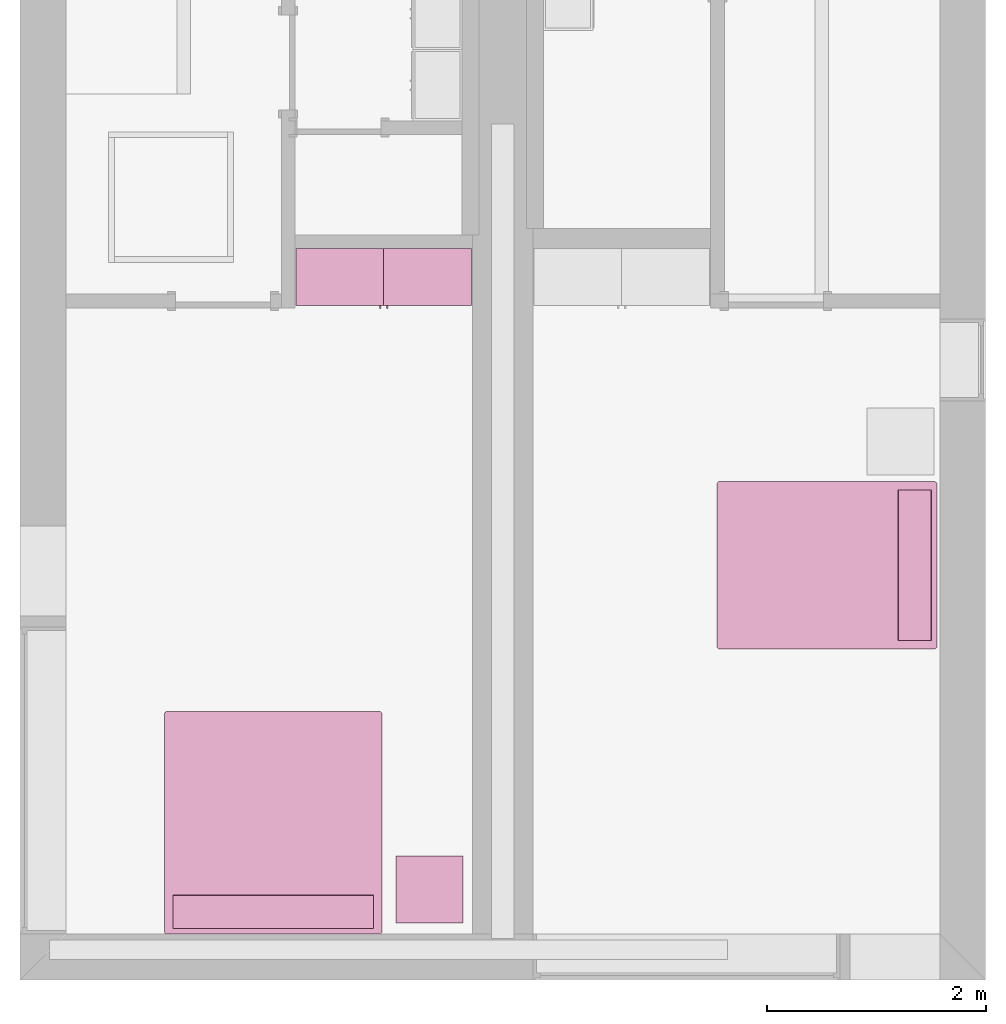
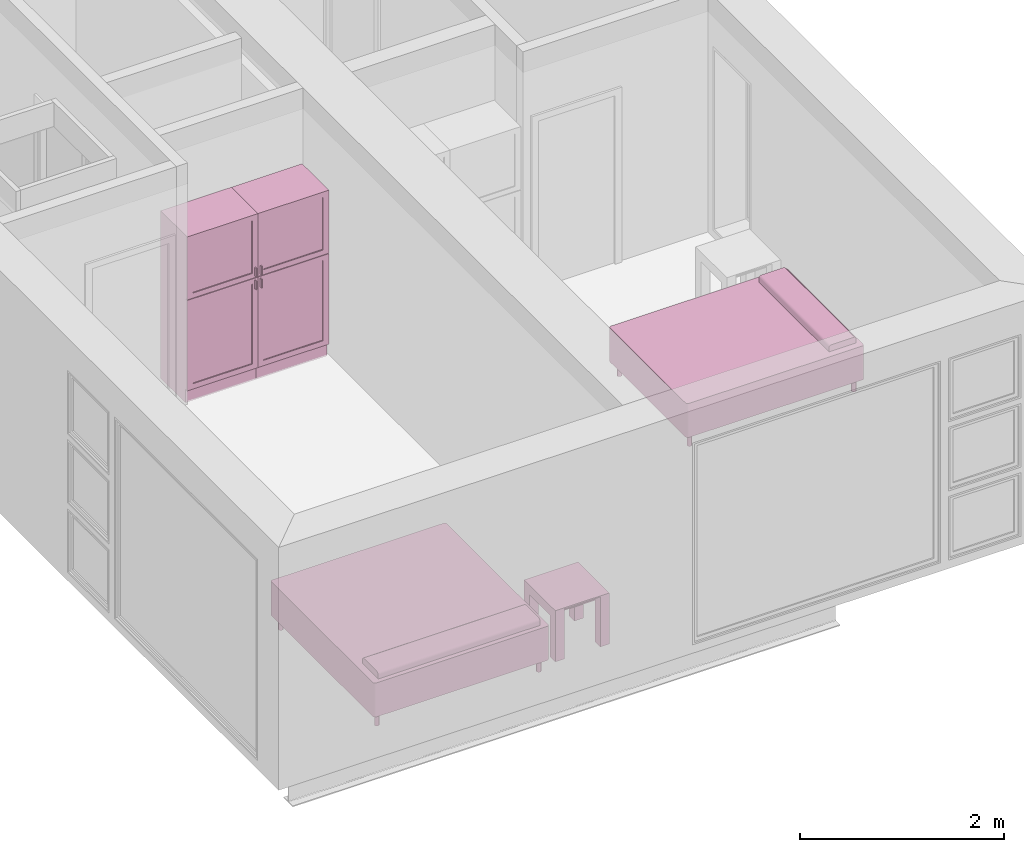
# One storey, part 7 of 10: 5 furnishings, 2 openings.
"""IFC2X3 building model written with IfcOpenShell, lengths in metres."""

from ifc_helpers import new_model, entity, si_unit, converted_unit, derived_unit, direction, frame, frame_2d, origin, origin_2d_with_axis, place, context, subcontext, project, spatial, polyline, circle_curve, parameter, trimmed, segment, composite_curve, rectangle, circle, outline, extrude, source, transform, mapped, material, material_list, type_object, type_shapes, element, save


model = new_model("IFC2X3")

# Units and contexts
model_context = context("Model", 3, precision=1e-05, world=origin(), true_north=direction((6.12303176911189e-17, 1.0)))
body_context = subcontext(model_context, "Body", "Model", "MODEL_VIEW")
ifc_project = project(units=[derived_unit("USERDEFINED", [(si_unit("LENGTHUNIT", "METRE"), -2), (si_unit("TIMEUNIT", "SECOND"), -2), (si_unit("MASSUNIT", "GRAM", prefix="KILO"), 1)]), si_unit("FREQUENCYUNIT", "HERTZ"), si_unit("LENGTHUNIT", "METRE"), si_unit("ILLUMINANCEUNIT", "LUX"), derived_unit("LINEARVELOCITYUNIT", [(si_unit("TIMEUNIT", "SECOND"), -1), (si_unit("LENGTHUNIT", "METRE"), 1)]), si_unit("POWERUNIT", "WATT"), si_unit("LUMINOUSINTENSITYUNIT", "CANDELA"), si_unit("AREAUNIT", "SQUARE_METRE"), si_unit("VOLUMEUNIT", "CUBIC_METRE"), si_unit("ELECTRICVOLTAGEUNIT", "VOLT"), si_unit("PRESSUREUNIT", "PASCAL"), converted_unit("PLANEANGLEUNIT", "DEGREE", entity("IfcRatioMeasure", 0.0174532925199433), si_unit("PLANEANGLEUNIT", "RADIAN"), dimensions=[0, 0, 0, 0, 0, 0, 0]), si_unit("THERMODYNAMICTEMPERATUREUNIT", "DEGREE_CELSIUS"), si_unit("MASSUNIT", "GRAM", prefix="KILO"), derived_unit("VOLUMETRICFLOWRATEUNIT", [(si_unit("LENGTHUNIT", "METRE"), 3), (si_unit("TIMEUNIT", "SECOND"), -1)]), si_unit("TIMEUNIT", "SECOND"), si_unit("LUMINOUSFLUXUNIT", "LUMEN"), derived_unit("USERDEFINED", [(si_unit("LUMINOUSFLUXUNIT", "LUMEN"), 1), (si_unit("TIMEUNIT", "SECOND"), 3), (si_unit("MASSUNIT", "GRAM", prefix="KILO"), -1), (si_unit("LENGTHUNIT", "METRE"), -2)]), si_unit("FORCEUNIT", "NEWTON", prefix="KILO"), si_unit("ELECTRICCURRENTUNIT", "AMPERE"), derived_unit("THERMALTRANSMITTANCEUNIT", [(si_unit("TIMEUNIT", "SECOND"), -3), (si_unit("THERMODYNAMICTEMPERATUREUNIT", "KELVIN"), -1), (si_unit("MASSUNIT", "GRAM", prefix="KILO"), 1)])], contexts=[model_context])

# Site, building, storey, space
site_placement = place(None, origin())
site = spatial("IfcSite", under=ifc_project, at=site_placement, CompositionType="ELEMENT")
building_placement = place(site_placement, origin())
building = spatial("IfcBuilding", under=site, at=building_placement, CompositionType="ELEMENT")
storey_placement = place(building_placement, frame((0.0, 0.0, 3.10000000000038)))
storey = spatial("IfcBuildingStorey", under=building, at=storey_placement, Name="Level 2", CompositionType="ELEMENT", Elevation=3.10000000000038)
space_1_placement = place(storey_placement, origin())
space_1 = spatial("IfcSpace", under=storey, at=space_1_placement, CompositionType="ELEMENT", InteriorOrExteriorSpace="INTERNAL")

# Furnishing, opening
ifc_material_1 = material(Name="Cabinets")
ifc_material_2 = material(Name="Cabinets - Handles")
ifc_material_3 = material(Name="Cabinets - Panel")
ifc_material_list_1 = material_list([ifc_material_1, ifc_material_2, ifc_material_3])
ifc_material_list_2 = material_list([ifc_material_1, ifc_material_2, ifc_material_3])
furniture_type_1 = type_object("IfcFurnitureType", Name="800 mm", AssemblyPlace="NOTDEFINED", material=ifc_material_list_2)
shared_shape_1 = source(origin(), body_context, "Body", "SweptSolid", [
    extrude(rectangle(XDim=0.00634999999999998, YDim=0.672999999999998, at=origin_2d_with_axis()), frame((0.0187377049180256, -0.504125, 0.225087499999839), z_axis=(0.0, 0.0, 1.0), x_axis=(0.0, 1.0, 0.0)), (0.0, 0.0, 1.0), 0.955960536695974),
    extrude(rectangle(XDim=0.0254, YDim=0.0125322316306447, at=frame_2d((0.0, -3.38271077815477e-17), x_axis=(1.0, 0.0))), frame((0.387071589102702, -0.532700000000001, 1.11754803669582), z_axis=(0.0, 0.0, 1.0), x_axis=(0.0, 1.0, 0.0)), (0.0, 0.0, 1.0), 0.101599999999998),
    extrude(rectangle(XDim=0.00634999999999998, YDim=0.672999999999998, at=origin_2d_with_axis()), frame((0.0187377049180261, -0.504125, 1.30804803669582), z_axis=(0.0, 0.0, 1.0), x_axis=(0.0, 1.0, 0.0)), (0.0, 0.0, 1.0), 0.62845196330414),
    extrude(outline(polyline([(-0.172299999999634, 0.558941666666897), (-0.172300000000835, -1.2794708333333), (0.328649999999164, -1.27947083333363), (0.32865000000047, 0.720529166666412), (-0.156349999999529, 0.720529166666729), (-0.156349999999635, 0.558941666666897), (-0.172299999999634, 0.558941666666897)])), frame((-0.381262295081959, -0.328649999999999, 0.720529166666627), z_axis=(-1.0, 0.0, 0.0), x_axis=(0.0, 1.0, 0.0)), (0.0, 0.0, -1.0), 0.8),
    extrude(outline(polyline([(-0.376138481652111, -0.4), (0.376138481652111, -0.4), (0.376138481652111, 0.4), (-0.376138481652111, 0.4), (-0.376138481652111, -0.4)]), holes=[polyline([(-0.312638481652032, -0.336499999999999), (-0.312638481652032, 0.336499999999999), (0.315813481652108, 0.336499999999999), (0.315813481652108, -0.336499999999999), (-0.312638481652032, -0.336499999999999)])]), frame((0.0187377049180258, -0.52, 1.62386151834792), z_axis=(0.0, 1.0, 0.0), x_axis=(0.0, 0.0, -1.0)), (0.0, 0.0, 1.0), 0.01905),
    extrude(outline(polyline([(-0.4, -0.539892768347997), (0.4, -0.539892768347997), (0.4, 0.539892768347997), (-0.4, 0.539892768347997), (-0.4, -0.539892768347997)]), holes=[polyline([(-0.336499999999999, 0.479567768347999), (0.336499999999999, 0.479567768347999), (0.336499999999999, -0.476392768347979), (-0.336499999999999, -0.476392768347979), (-0.336499999999999, 0.479567768347999)])]), frame((0.0187377049180257, -0.52, 0.701480268347818), z_axis=(0.0, 1.0, 0.0), x_axis=(-1.0, 0.0, 0.0)), (0.0, 0.0, 1.0), 0.01905),
    extrude(rectangle(XDim=0.0254, YDim=0.0125322316306444, at=frame_2d((0.0, 3.38271077815477e-17), x_axis=(1.0, 0.0))), frame((0.387071589102703, -0.532700000000001, 1.26994803669581), z_axis=(0.0, 0.0, 1.0), x_axis=(0.0, 1.0, 0.0)), (0.0, 0.0, 1.0), 0.1016),
    extrude(rectangle(XDim=0.01905, YDim=0.761899999999999, at=origin_2d_with_axis()), frame((0.018737704918025, -0.009525, 0.180637499999846), z_axis=(0.0, 0.0, 1.0), x_axis=(0.0, 1.0, 0.0)), (0.0, 0.0, 1.0), 1.80031250000011),
])
type_shapes(furniture_type_1, [shared_shape_1])
furnishing_1_placement = place(space_1_placement, frame((2.89526229508197, -11.134, 0.0)))
furnishing_1 = element("IfcFurnishingElement", 1, at=furnishing_1_placement, inside=space_1, type_object=furniture_type_1, material=ifc_material_list_1, ObjectType="800 mm", context=body_context, shape_type="MappedRepresentation", body=[
    mapped(shared_shape_1, transform((0.0, 0.0, 0.0), scale=1.0)),
])
opening_1_placement = place(storey_placement, frame((2.89526229508197, -11.134, 3.1000000000002)))
element("IfcOpeningElement", 2, at=opening_1_placement, cuts=furnishing_1, ObjectType="Opening", context=body_context, shape_type="SweptSolid", body=[
    extrude(rectangle(XDim=1.80031250000011, YDim=0.761899999999999, at=frame_2d((5.55111512312578e-17, 0.0), x_axis=(1.0, 0.0))), frame((0.0187377049180235, -0.50095, -2.01920625000048), z_axis=(0.0, 1.0, 0.0), x_axis=(0.0, 0.0, -1.0)), (0.0, 0.0, 1.0), 0.50095),
])

ifc_material_list_3 = material_list([ifc_material_1, ifc_material_2, ifc_material_3])
ifc_material_list_4 = material_list([ifc_material_1, ifc_material_2, ifc_material_3])
furniture_type_2 = type_object("IfcFurnitureType", Name="800 mm", AssemblyPlace="NOTDEFINED", material=ifc_material_list_4)
shared_shape_2 = source(origin(), body_context, "Body", "SweptSolid", [
    extrude(rectangle(XDim=0.0125322316306447, YDim=0.0254, at=frame_2d((-3.38271077815477e-17, 0.0), x_axis=(1.0, 0.0))), frame((0.387071589102702, 0.532700000000001, 1.11754803669582), z_axis=(0.0, 0.0, 1.0), x_axis=(-1.0, 0.0, 0.0)), (0.0, 0.0, 1.0), 0.101599999999998),
    extrude(rectangle(XDim=0.672999999999998, YDim=0.00634999999999998, at=frame_2d((0.0, 6.76542155630955e-17), x_axis=(1.0, 0.0))), frame((0.0187377049180256, 0.504125, 0.225087499999839), z_axis=(0.0, 0.0, 1.0), x_axis=(-1.0, 0.0, 0.0)), (0.0, 0.0, 1.0), 0.955960536695974),
    extrude(rectangle(XDim=0.672999999999998, YDim=0.00634999999999998, at=frame_2d((0.0, 6.76542155630955e-17), x_axis=(1.0, 0.0))), frame((0.0187377049180261, 0.504125, 1.30804803669582), z_axis=(0.0, 0.0, 1.0), x_axis=(-1.0, 0.0, 0.0)), (0.0, 0.0, 1.0), 0.62845196330414),
    extrude(outline(polyline([(-0.558941666666786, -0.172299999999999), (1.27947083333342, -0.172299999999999), (1.27947083333342, 0.32865), (-0.720529166666629, 0.328649999999999), (-0.720529166666629, -0.15635), (-0.558941666666786, -0.15635), (-0.558941666666786, -0.172299999999999)])), frame((-0.38126229508196, 0.328649999999999, 0.720529166666629), z_axis=(1.0, 0.0, 0.0), x_axis=(0.0, 0.0, 1.0)), (0.0, 0.0, 1.0), 0.8),
    extrude(outline(polyline([(-0.4, -0.539892768347997), (0.4, -0.539892768347997), (0.4, 0.539892768347997), (-0.4, 0.539892768347997), (-0.4, -0.539892768347997)]), holes=[polyline([(-0.336499999999999, 0.479567768347999), (0.336499999999999, 0.479567768347999), (0.336499999999999, -0.476392768347979), (-0.336499999999999, -0.476392768347979), (-0.336499999999999, 0.479567768347999)])]), frame((0.0187377049180257, 0.50095, 0.701480268347818), z_axis=(0.0, 1.0, 0.0), x_axis=(-1.0, 0.0, 0.0)), (0.0, 0.0, 1.0), 0.01905),
    extrude(rectangle(XDim=0.0125322316306444, YDim=0.0254, at=frame_2d((3.38271077815477e-17, 0.0), x_axis=(1.0, 0.0))), frame((0.387071589102703, 0.532700000000001, 1.26994803669581), z_axis=(0.0, 0.0, 1.0), x_axis=(-1.0, 0.0, 0.0)), (0.0, 0.0, 1.0), 0.1016),
    extrude(outline(polyline([(-0.376138481652111, -0.4), (0.376138481652111, -0.4), (0.376138481652111, 0.4), (-0.376138481652111, 0.4), (-0.376138481652111, -0.4)]), holes=[polyline([(-0.312638481652032, -0.3365), (-0.312638481652032, 0.336499999999999), (0.315813481652108, 0.336499999999999), (0.315813481652108, -0.3365), (-0.312638481652032, -0.3365)])]), frame((0.0187377049180258, 0.50095, 1.62386151834792), z_axis=(0.0, 1.0, 0.0), x_axis=(0.0, 0.0, -1.0)), (0.0, 0.0, 1.0), 0.01905),
    extrude(rectangle(XDim=0.761899999999999, YDim=0.01905, at=origin_2d_with_axis()), frame((0.018737704918025, 0.009525, 0.180637499999846), z_axis=(0.0, 0.0, 1.0), x_axis=(-1.0, 0.0, 0.0)), (0.0, 0.0, 1.0), 1.80031250000011),
])
type_shapes(furniture_type_2, [shared_shape_2])
furnishing_2_placement = place(space_1_placement, frame((3.73273770491802, -11.134, 0.0), z_axis=(0.0, 0.0, 1.0), x_axis=(-1.0, 0.0, 0.0)))
furnishing_2 = element("IfcFurnishingElement", 3, at=furnishing_2_placement, inside=space_1, type_object=furniture_type_2, material=ifc_material_list_3, ObjectType="800 mm", context=body_context, shape_type="MappedRepresentation", body=[
    mapped(shared_shape_2, transform((0.0, 0.0, 0.0), scale=1.0)),
])
opening_2_placement = place(storey_placement, frame((3.73273770491802, -11.134, 3.1000000000002)))
element("IfcOpeningElement", 4, at=opening_2_placement, cuts=furnishing_2, ObjectType="Opening", context=body_context, shape_type="SweptSolid", body=[
    extrude(rectangle(XDim=1.80031250000011, YDim=0.761899999999999, at=frame_2d((5.55111512312578e-17, 0.0), x_axis=(1.0, 0.0))), frame((-0.0187377049180251, 0.0, -2.01920625000048), z_axis=(0.0, -1.0, 0.0), x_axis=(0.0, 0.0, -1.0)), (0.0, 0.0, 1.0), 0.50095),
])

# Furnishing
ifc_material_4 = material(Name="Wood - Teak")
ifc_material_5 = material(Name="Glass - Clear, Grey")
ifc_material_6 = material(Name="Metal - Chrome")
ifc_material_list_5 = material_list([ifc_material_4, ifc_material_5, ifc_material_6])
ifc_material_list_6 = material_list([ifc_material_4, ifc_material_5, ifc_material_6])
furniture_type_3 = type_object("IfcFurnitureType", Name="0610 x 0610 x 0610mm", AssemblyPlace="NOTDEFINED", material=ifc_material_list_6)
shared_shape_3 = source(origin(), body_context, "Body", "SweptSolid", [
    extrude(rectangle(XDim=0.406799999999999, YDim=0.4068, at=origin_2d_with_axis()), frame((0.0182657666726316, 0.0952110778022263, 0.4957), z_axis=(0.0, 0.0, 1.0), x_axis=(-1.0, 0.0, 0.0)), (0.0, 0.0, 1.0), 0.0127),
    extrude(outline(polyline([(-0.273249999999994, -0.305), (0.324049999999978, -0.305), (0.324049999999978, 0.304999999999998), (-0.273249999999993, 0.304999999999999), (-0.273249999999993, 0.203400000000001), (0.222450000000009, 0.203400000000001), (0.222450000000009, -0.2034), (-0.273249999999994, -0.2034), (-0.273249999999994, -0.305)])), frame((0.221665766672633, 0.0952110778022354, 0.273249999999992), z_axis=(1.0, 0.0, 0.0), x_axis=(0.0, 0.0, 1.0)), (0.0, 0.0, 1.0), 0.1016),
    extrude(outline(polyline([(-0.305, -0.305000000000023), (0.305, -0.305000000000023), (0.305, 0.305000000000023), (-0.305, 0.305000000000023), (-0.305, -0.305000000000023)]), holes=[polyline([(-0.203399999999998, -0.203399999999975), (-0.203399999999998, 0.203400000000025), (0.203400000000001, 0.203400000000025), (0.203400000000001, -0.203399999999975), (-0.203399999999998, -0.203399999999975)])]), frame((0.0182657666726332, 0.0952110778022508, 0.5973), z_axis=(0.0, 0.0, 1.0), x_axis=(-1.0, 0.0, 0.0)), (0.0, 0.0, 1.0), 0.0127),
    extrude(outline(polyline([(-0.305000000000004, -0.324050000000026), (0.304999999999994, -0.324050000000026), (0.304999999999994, 0.273250000000011), (0.203400000000004, 0.273250000000011), (0.203400000000004, -0.222449999999996), (-0.203399999999994, -0.222449999999996), (-0.203399999999994, 0.273250000000011), (-0.305000000000004, 0.273250000000011), (-0.305000000000004, -0.324050000000026)])), frame((-0.286734233327367, 0.0952110778022256, 0.273250000000008), z_axis=(1.0, 0.0, 0.0), x_axis=(0.0, -1.0, 0.0)), (0.0, 0.0, 1.0), 0.1016),
    extrude(rectangle(XDim=0.406799999999999, YDim=0.4068, at=origin_2d_with_axis()), frame((0.0182657666726316, 0.0952110778022259, 0.5973), z_axis=(0.0, 0.0, 1.0), x_axis=(-1.0, 0.0, 0.0)), (0.0, 0.0, 1.0), 0.0127),
])
type_shapes(furniture_type_3, [shared_shape_3])
furnishing_3_placement = place(space_1_placement, frame((3.71173423332735, -17.0692110778022, 0.0189999999998181)))
element("IfcFurnishingElement", 5, at=furnishing_3_placement, inside=space_1, type_object=furniture_type_3, material=ifc_material_list_5, Name="M_Table-Coffee:0610 x 0610 x 0610mm", ObjectType="0610 x 0610 x 0610mm", context=body_context, shape_type="MappedRepresentation", body=[
    mapped(shared_shape_3, transform((0.0, 0.0, 0.0), scale=1.0)),
])

# Space
space_2_placement = place(storey_placement, origin())
space_2 = spatial("IfcSpace", under=storey, at=space_2_placement, CompositionType="ELEMENT", InteriorOrExteriorSpace="INTERNAL")

# Furnishings
ifc_material_7 = material(Name="Textile - White")
ifc_material_list_7 = material_list([ifc_material_7, ifc_material_6])
ifc_material_list_8 = material_list([ifc_material_7, ifc_material_6])
furniture_type_4 = type_object("IfcFurnitureType", Name="1525 x 2007mm - Queen", AssemblyPlace="NOTDEFINED", material=ifc_material_list_8)
shared_shape_4 = source(origin(), body_context, "Body", "SweptSolid", [
    extrude(outline(composite_curve([segment(polyline([(-0.1524, -0.0423333333333332), (0.1524, -0.0423333333333332)]), True, "CONTINUOUS"), segment(polyline([(0.1524, -0.0423333333333332), (0.1524, 0.00846666666666662)]), True, "CONTINUOUS"), segment(trimmed(circle_curve(frame_2d((0.127, 0.00846666666666662), x_axis=(-1.0, 0.0)), 0.0254), [parameter(180.0)], [parameter(270.0)], True, "PARAMETER"), True, "CONTINUOUS"), segment(polyline([(0.127, 0.0338666666666666), (-0.127, 0.0338666666666666)]), True, "CONTINUOUS"), segment(trimmed(circle_curve(frame_2d((-0.127, 0.00846666666666673), x_axis=(-1.0, 0.0)), 0.0254), [parameter(270.0)], [parameter(0.0)], True, "PARAMETER"), True, "CONTINUOUS"), segment(polyline([(-0.1524, 0.00846666666666673), (-0.1524, -0.0423333333333332)]), True, "CONTINUOUS")], self_intersect=False)), frame((-0.414811475409804, 0.754704918032813, 0.601133333333333), z_axis=(1.0, 0.0, 0.0), x_axis=(0.0, 1.0, 0.0)), (0.0, 0.0, 1.0), 1.37259999999997),
    extrude(circle(Radius=0.0253999999999999, at=origin_2d_with_axis()), frame((-0.414811475409829, 0.881704918032795, 0.0)), (0.0, 0.0, 1.0), 0.1524),
    extrude(circle(Radius=0.0254000000000034, at=frame_2d((-6.76791955811495e-17, -1.35358391162299e-16), x_axis=(1.0, 0.0))), frame((-0.414811475409807, -0.972895081967205, 0.0)), (0.0, 0.0, 1.0), 0.1524),
    extrude(circle(Radius=0.0254000000000244, at=origin_2d_with_axis()), frame((0.957788524590165, 0.881704918032822, 0.0)), (0.0, 0.0, 1.0), 0.1524),
    extrude(outline(composite_curve([segment(trimmed(circle_curve(frame_2d((-0.737099999999989, -0.978100000000009), x_axis=(1.0, 0.0)), 0.0254000000000003), [parameter(180.0)], [parameter(270.0)], True, "PARAMETER"), True, "CONTINUOUS"), segment(polyline([(-0.737099999999989, -1.00350000000001), (0.737100000000009, -1.00350000000001)]), True, "CONTINUOUS"), segment(trimmed(circle_curve(frame_2d((0.737100000000009, -0.978100000000034), x_axis=(1.0, 0.0)), 0.0253999999999749), [parameter(270.0)], [parameter(360.0)], True, "PARAMETER"), True, "CONTINUOUS"), segment(polyline([(0.762499999999984, -0.978100000000034), (0.762499999999984, 0.97810000000004)]), True, "CONTINUOUS"), segment(trimmed(circle_curve(frame_2d((0.737100000000033, 0.97810000000004), x_axis=(1.0, 0.0)), 0.0253999999999504), [parameter(0.0)], [parameter(90.0000000000001)], True, "PARAMETER"), True, "CONTINUOUS"), segment(polyline([(0.737100000000033, 1.00349999999999), (-0.737100000000041, 1.00349999999999)]), True, "CONTINUOUS"), segment(trimmed(circle_curve(frame_2d((-0.737100000000041, 0.978100000000042), x_axis=(1.0, 0.0)), 0.0253999999999488), [parameter(90.0000000000001)], [parameter(180.0)], True, "PARAMETER"), True, "CONTINUOUS"), segment(polyline([(-0.76249999999999, 0.978100000000042), (-0.76249999999999, -0.978100000000009)]), True, "CONTINUOUS")], self_intersect=False)), frame((0.271488524590183, -0.0455950819671924, 0.1524)), (0.0, 0.0, 1.0), 0.2032),
    extrude(circle(Radius=0.0254, at=frame_2d((0.0, -1.35358391162299e-16), x_axis=(1.0, 0.0))), frame((0.957788524590184, -0.972895081967175, 0.0)), (0.0, 0.0, 1.0), 0.1524),
    extrude(outline(composite_curve([segment(trimmed(circle_curve(frame_2d((-0.73710000000004, 0.978100000000041), x_axis=(1.0, 0.0)), 0.0253999999999498), [parameter(90.0000000000001)], [parameter(180.0)], True, "PARAMETER"), True, "CONTINUOUS"), segment(polyline([(-0.76249999999999, 0.978100000000041), (-0.76249999999999, -0.978100000000009)]), True, "CONTINUOUS"), segment(trimmed(circle_curve(frame_2d((-0.737099999999989, -0.978100000000009), x_axis=(1.0, 0.0)), 0.0254000000000007), [parameter(180.0)], [parameter(270.0)], True, "PARAMETER"), True, "CONTINUOUS"), segment(polyline([(-0.737099999999989, -1.00350000000001), (0.737100000000009, -1.00350000000001)]), True, "CONTINUOUS"), segment(trimmed(circle_curve(frame_2d((0.737100000000009, -0.978100000000035), x_axis=(1.0, 0.0)), 0.0253999999999751), [parameter(270.0)], [parameter(359.999999999999)], True, "PARAMETER"), True, "CONTINUOUS"), segment(polyline([(0.762499999999984, -0.978100000000035), (0.762499999999984, 0.978100000000041)]), True, "CONTINUOUS"), segment(trimmed(circle_curve(frame_2d((0.737100000000034, 0.978100000000041), x_axis=(1.0, 0.0)), 0.0253999999999497), [parameter(360.0)], [parameter(89.9999999999998)], True, "PARAMETER"), True, "CONTINUOUS"), segment(polyline([(0.737100000000034, 1.00349999999999), (-0.737100000000041, 1.00349999999999)]), True, "CONTINUOUS")], self_intersect=False)), frame((0.271488524590183, -0.045595081967192, 0.3556)), (0.0, 0.0, 1.0), 0.2032),
])
type_shapes(furniture_type_4, [shared_shape_4])
furnishing_4_placement = place(space_2_placement, frame((7.3990950819672, -13.7490114754098, 0.0), z_axis=(0.0, 0.0, 1.0), x_axis=(0.0, -1.0, 0.0)))
element("IfcFurnishingElement", 6, at=furnishing_4_placement, inside=space_2, type_object=furniture_type_4, material=ifc_material_list_7, Name="M_Bed-Standard:1525 x 2007mm - Queen", ObjectType="1525 x 2007mm - Queen", context=body_context, shape_type="MappedRepresentation", body=[
    mapped(shared_shape_4, transform((0.0, 0.0, 0.0), scale=1.0)),
])
ifc_material_list_9 = material_list([ifc_material_7, ifc_material_6])
ifc_material_list_10 = material_list([ifc_material_7, ifc_material_6])
furniture_type_5 = type_object("IfcFurnitureType", Name="1981 x 2032mm - King", AssemblyPlace="NOTDEFINED", material=ifc_material_list_10)
shared_shape_5 = source(origin(), body_context, "Body", "SweptSolid", [
    extrude(outline(composite_curve([segment(polyline([(-0.1524, -0.0423333333333332), (0.1524, -0.0423333333333332)]), True, "CONTINUOUS"), segment(polyline([(0.1524, -0.0423333333333332), (0.1524, 0.00846666666666662)]), True, "CONTINUOUS"), segment(trimmed(circle_curve(frame_2d((0.127, 0.00846666666666662), x_axis=(-1.0, 0.0)), 0.0254), [parameter(180.0)], [parameter(270.0)], True, "PARAMETER"), True, "CONTINUOUS"), segment(polyline([(0.127, 0.0338666666666666), (-0.127, 0.0338666666666666)]), True, "CONTINUOUS"), segment(trimmed(circle_curve(frame_2d((-0.127, 0.00846666666666673), x_axis=(-1.0, 0.0)), 0.0254), [parameter(270.0)], [parameter(0.0)], True, "PARAMETER"), True, "CONTINUOUS"), segment(polyline([(-0.1524, 0.00846666666666673), (-0.1524, -0.0423333333333332)]), True, "CONTINUOUS")], self_intersect=False)), frame((-0.642811475409803, 0.767204918032816, 0.601133333333333), z_axis=(1.0, 0.0, 0.0), x_axis=(0.0, 1.0, 0.0)), (0.0, 0.0, 1.0), 1.82859999999997),
    extrude(circle(Radius=0.0254000000000034, at=frame_2d((0.0, -1.35358391162299e-16), x_axis=(1.0, 0.0))), frame((-0.642811475409802, -0.985395081967205, 0.0)), (0.0, 0.0, 1.0), 0.1524),
    extrude(outline(composite_curve([segment(trimmed(circle_curve(frame_2d((-0.965099999999988, -0.990600000000012), x_axis=(1.0, 0.0)), 0.0254000000000003), [parameter(180.0)], [parameter(270.0)], True, "PARAMETER"), True, "CONTINUOUS"), segment(polyline([(-0.965099999999988, -1.01600000000001), (0.965100000000011, -1.01600000000001)]), True, "CONTINUOUS"), segment(trimmed(circle_curve(frame_2d((0.965100000000011, -0.990600000000044), x_axis=(1.0, 0.0)), 0.0253999999999749), [parameter(270.0)], [parameter(360.0)], True, "PARAMETER"), True, "CONTINUOUS"), segment(polyline([(0.990499999999986, -0.990600000000044), (0.99049999999998, 0.990600000000046)]), True, "CONTINUOUS"), segment(trimmed(circle_curve(frame_2d((0.965100000000038, 0.990600000000046), x_axis=(1.0, 0.0)), 0.0253999999999504), [parameter(3.05333249420498e-13)], [parameter(89.9999999999995)], True, "PARAMETER"), True, "CONTINUOUS"), segment(polyline([(0.965100000000038, 1.016), (-0.965100000000049, 1.01599999999999)]), True, "CONTINUOUS"), segment(trimmed(circle_curve(frame_2d((-0.965100000000049, 0.990600000000048), x_axis=(1.0, 0.0)), 0.0253999999999488), [parameter(90.0000000000001)], [parameter(180.0)], True, "PARAMETER"), True, "CONTINUOUS"), segment(polyline([(-0.990499999999998, 0.990600000000048), (-0.990499999999989, -0.990600000000012)]), True, "CONTINUOUS")], self_intersect=False)), frame((0.271488524590187, -0.0455950819671894, 0.1524)), (0.0, 0.0, 1.0), 0.2032),
    extrude(circle(Radius=0.0254, at=frame_2d((0.0, -1.35358391162299e-16), x_axis=(1.0, 0.0))), frame((1.18578852459019, -0.985395081967167, 0.0)), (0.0, 0.0, 1.0), 0.1524),
    extrude(circle(Radius=0.0254000000000244, at=frame_2d((-1.35358391162299e-16, -1.35358391162299e-16), x_axis=(1.0, 0.0))), frame((1.18578852459016, 0.894204918032828, 0.0)), (0.0, 0.0, 1.0), 0.1524),
    extrude(circle(Radius=0.0253999999999999, at=frame_2d((0.0, -1.35358391162299e-16), x_axis=(1.0, 0.0))), frame((-0.642811475409827, 0.894204918032794, 0.0)), (0.0, 0.0, 1.0), 0.1524),
    extrude(outline(composite_curve([segment(trimmed(circle_curve(frame_2d((-0.965100000000049, 0.990600000000047), x_axis=(1.0, 0.0)), 0.0253999999999498), [parameter(90.0000000000001)], [parameter(180.0)], True, "PARAMETER"), True, "CONTINUOUS"), segment(polyline([(-0.990499999999999, 0.990600000000047), (-0.990499999999989, -0.990600000000012)]), True, "CONTINUOUS"), segment(trimmed(circle_curve(frame_2d((-0.965099999999988, -0.990600000000011), x_axis=(1.0, 0.0)), 0.0254000000000007), [parameter(180.0)], [parameter(270.0)], True, "PARAMETER"), True, "CONTINUOUS"), segment(polyline([(-0.965099999999989, -1.01600000000001), (0.965100000000011, -1.01600000000001)]), True, "CONTINUOUS"), segment(trimmed(circle_curve(frame_2d((0.965100000000011, -0.990600000000044), x_axis=(1.0, 0.0)), 0.0253999999999751), [parameter(269.999999999999)], [parameter(360.0)], True, "PARAMETER"), True, "CONTINUOUS"), segment(polyline([(0.990499999999986, -0.990600000000044), (0.99049999999998, 0.990600000000047)]), True, "CONTINUOUS"), segment(trimmed(circle_curve(frame_2d((0.965100000000039, 0.990600000000047), x_axis=(1.0, 0.0)), 0.0253999999999497), [parameter(360.0)], [parameter(89.9999999999995)], True, "PARAMETER"), True, "CONTINUOUS"), segment(polyline([(0.965100000000039, 1.016), (-0.965100000000049, 1.01599999999999)]), True, "CONTINUOUS")], self_intersect=False)), frame((0.271488524590187, -0.0455950819671895, 0.3556)), (0.0, 0.0, 1.0), 0.2032),
])
type_shapes(furniture_type_5, [shared_shape_5])
furnishing_5_placement = place(space_1_placement, frame((2.57898852459016, -16.4125950819672, 0.0), z_axis=(0.0, 0.0, 1.0), x_axis=(-1.0, 0.0, 0.0)))
element("IfcFurnishingElement", 7, at=furnishing_5_placement, inside=space_1, type_object=furniture_type_5, material=ifc_material_list_9, Name="M_Bed-Standard:1981 x 2032mm - King", ObjectType="1981 x 2032mm - King", context=body_context, shape_type="MappedRepresentation", body=[
    mapped(shared_shape_5, transform((0.0, 0.0, 0.0), scale=1.0)),
])

save(model, "model.ifc")
